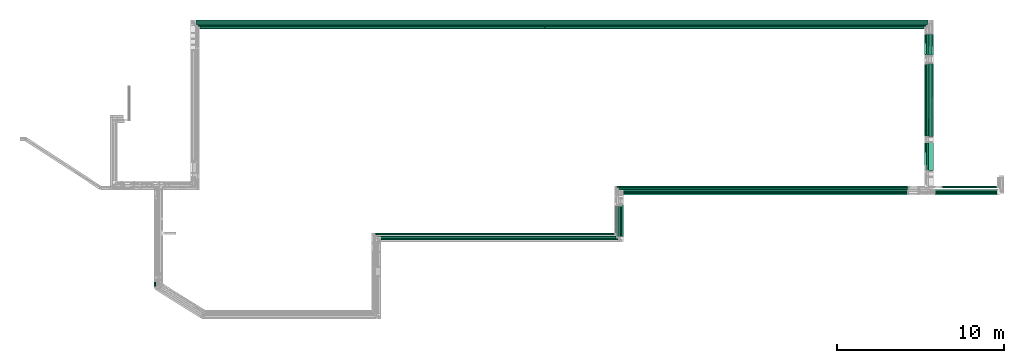
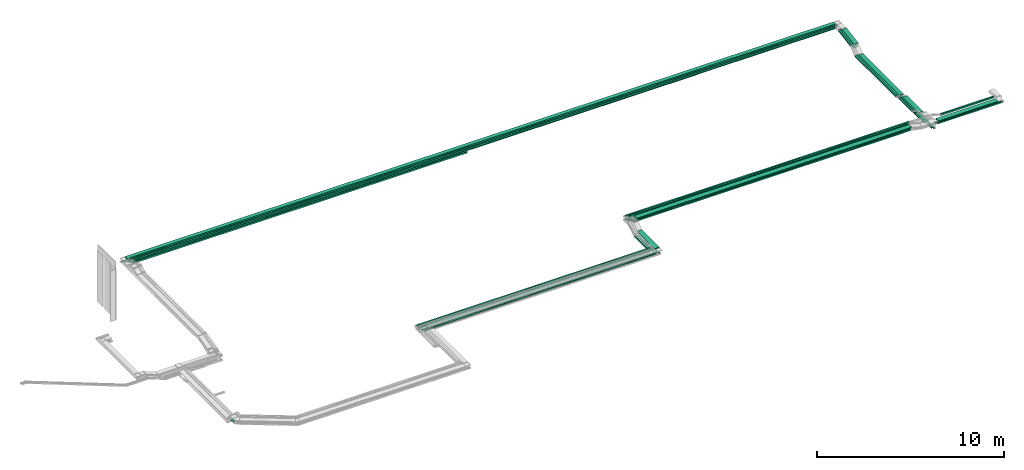
# One storey, part 2 of 14: 43 flow segments.
"""IFC2X3 building model written with IfcOpenShell, lengths in millimetres."""

from ifc_helpers import new_model, entity, si_unit, converted_unit, derived_unit, direction, frame, frame_2d, origin, origin_2d_with_axis, place, context, subcontext, project, spatial, rectangle, extrude, type_object, element, save


model = new_model("IFC2X3")

# Units and contexts
model_context = context("Model", 3, precision=0.01, world=origin(), true_north=direction((6.12303176911189e-17, 1.0)))
body_context = subcontext(model_context, "Body", "Model", "MODEL_VIEW")
ifc_project = project(units=[si_unit("LENGTHUNIT", "METRE", prefix="MILLI"), si_unit("AREAUNIT", "SQUARE_METRE"), si_unit("VOLUMEUNIT", "CUBIC_METRE"), converted_unit("PLANEANGLEUNIT", "DEGREE", entity("IfcRatioMeasure", 0.0174532925199433), si_unit("PLANEANGLEUNIT", "RADIAN"), dimensions=[0, 0, 0, 0, 0, 0, 0]), si_unit("MASSUNIT", "GRAM", prefix="KILO"), derived_unit("MASSDENSITYUNIT", [(si_unit("MASSUNIT", "GRAM", prefix="KILO"), 1), (si_unit("LENGTHUNIT", "METRE"), -3)]), derived_unit("MOMENTOFINERTIAUNIT", [(si_unit("LENGTHUNIT", "METRE"), 4)]), si_unit("TIMEUNIT", "SECOND"), si_unit("FREQUENCYUNIT", "HERTZ"), si_unit("THERMODYNAMICTEMPERATUREUNIT", "DEGREE_CELSIUS"), derived_unit("THERMALTRANSMITTANCEUNIT", [(si_unit("MASSUNIT", "GRAM", prefix="KILO"), 1), (si_unit("THERMODYNAMICTEMPERATUREUNIT", "KELVIN"), -1), (si_unit("TIMEUNIT", "SECOND"), -3)]), derived_unit("VOLUMETRICFLOWRATEUNIT", [(si_unit("LENGTHUNIT", "METRE"), 3), (si_unit("TIMEUNIT", "SECOND"), -1)]), derived_unit("MASSFLOWRATEUNIT", [(si_unit("MASSUNIT", "GRAM", prefix="KILO"), 1), (si_unit("TIMEUNIT", "SECOND"), -1)]), derived_unit("ROTATIONALFREQUENCYUNIT", [(si_unit("TIMEUNIT", "SECOND"), -1)]), si_unit("ELECTRICCURRENTUNIT", "AMPERE"), si_unit("ELECTRICVOLTAGEUNIT", "VOLT"), si_unit("POWERUNIT", "WATT"), si_unit("FORCEUNIT", "NEWTON", prefix="KILO"), si_unit("ILLUMINANCEUNIT", "LUX"), si_unit("LUMINOUSFLUXUNIT", "LUMEN"), si_unit("LUMINOUSINTENSITYUNIT", "CANDELA"), derived_unit("USERDEFINED", [(si_unit("MASSUNIT", "GRAM", prefix="KILO"), -1), (si_unit("LENGTHUNIT", "METRE"), -2), (si_unit("TIMEUNIT", "SECOND"), 3), (si_unit("LUMINOUSFLUXUNIT", "LUMEN"), 1)]), derived_unit("LINEARVELOCITYUNIT", [(si_unit("LENGTHUNIT", "METRE"), 1), (si_unit("TIMEUNIT", "SECOND"), -1)]), si_unit("PRESSUREUNIT", "PASCAL"), derived_unit("USERDEFINED", [(si_unit("LENGTHUNIT", "METRE"), -2), (si_unit("MASSUNIT", "GRAM", prefix="KILO"), 1), (si_unit("TIMEUNIT", "SECOND"), -2)]), derived_unit("LINEARFORCEUNIT", [(si_unit("MASSUNIT", "GRAM", prefix="KILO"), 1), (si_unit("LENGTHUNIT", "METRE"), 1), (si_unit("TIMEUNIT", "SECOND"), -2), (si_unit("LENGTHUNIT", "METRE"), -1)]), derived_unit("PLANARFORCEUNIT", [(si_unit("MASSUNIT", "GRAM", prefix="KILO"), 1), (si_unit("LENGTHUNIT", "METRE"), 1), (si_unit("TIMEUNIT", "SECOND"), -2), (si_unit("LENGTHUNIT", "METRE"), -2)])], contexts=[model_context])

# Site, building, storey
site_placement = place(None, origin())
site = spatial("IfcSite", under=ifc_project, at=site_placement, CompositionType="ELEMENT")
building_placement = place(site_placement, origin())
building = spatial("IfcBuilding", under=site, at=building_placement, CompositionType="ELEMENT")
storey_placement = place(building_placement, frame((0.0, 0.0, 19800.0)))
storey = spatial("IfcBuildingStorey", under=building, at=storey_placement, Name="06", CompositionType="ELEMENT", Elevation=19800.0)

# Flow segments
cable_carrier_segment_type = type_object("IfcCableCarrierSegmentType", PredefinedType="CABLETRAYSEGMENT")
flow_segment_1_placement = place(storey_placement, frame((20510.22, 19700.0, 3300.0)))
element("IfcFlowSegment", 1, at=flow_segment_1_placement, inside=storey, type_object=cable_carrier_segment_type, context=body_context, shape_type="SweptSolid", body=[
    extrude(rectangle(XDim=43861.6970823392, YDim=300.000000000001, at=origin_2d_with_axis()), frame((21930.85, 150.0, 0.0), z_axis=(3.27264479763197e-08, 0.0, 1.0), x_axis=(-1.0, 0.0, 3.27264479763197e-08)), (0.0, 0.0, 1.0), 49.9999999999973),
])
flow_segment_2_placement = place(storey_placement, frame((20615.22, 19595.0, 3300.0)))
element("IfcFlowSegment", 2, at=flow_segment_2_placement, inside=storey, type_object=cable_carrier_segment_type, context=body_context, shape_type="SweptSolid", body=[
    extrude(rectangle(XDim=43650.3107133575, YDim=100.000000000003, at=origin_2d_with_axis()), frame((21825.16, 50.0, 0.0), z_axis=(0.0, 0.0, 1.0), x_axis=(-1.0, 0.0, 0.0)), (0.0, 0.0, 1.0), 100.000000000003),
])
flow_segment_3_placement = place(storey_placement, frame((20720.22, 19490.0, 3300.0)))
element("IfcFlowSegment", 3, at=flow_segment_3_placement, inside=storey, type_object=cable_carrier_segment_type, context=body_context, shape_type="SweptSolid", body=[
    extrude(rectangle(XDim=43439.8425431613, YDim=100.000000000001, at=origin_2d_with_axis()), frame((21719.92, 50.0, 0.0), z_axis=(0.0, 0.0, 1.0), x_axis=(-1.0, 0.0, 0.0)), (0.0, 0.0, 1.0), 100.000000000003),
])
flow_segment_4_placement = place(storey_placement, frame((64593.04, 9615.0, 2550.0)))
element("IfcFlowSegment", 4, at=flow_segment_4_placement, inside=storey, type_object=cable_carrier_segment_type, context=body_context, shape_type="SweptSolid", body=[
    extrude(rectangle(XDim=7760.0992906484, YDim=99.9999999999946, at=origin_2d_with_axis()), frame((50.0, 3880.05, 0.0), z_axis=(0.0, 0.0, 1.0), x_axis=(0.0, -1.0, 0.0)), (0.0, 0.0, 1.0), 49.9999999999973),
])
flow_segment_5_placement = place(storey_placement, frame((64490.53, 9720.0, 2550.0)))
element("IfcFlowSegment", 5, at=flow_segment_5_placement, inside=storey, type_object=cable_carrier_segment_type, context=body_context, shape_type="SweptSolid", body=[
    extrude(rectangle(XDim=7655.09929065903, YDim=99.9999999999946, at=origin_2d_with_axis()), frame((50.0, 3827.55, 0.0), z_axis=(0.0, 0.0, 1.0), x_axis=(0.0, -1.0, 0.0)), (0.0, 0.0, 1.0), 49.9999999999973),
])
flow_segment_6_placement = place(storey_placement, frame((64388.57, 10290.0, 2550.0)))
element("IfcFlowSegment", 6, at=flow_segment_6_placement, inside=storey, type_object=cable_carrier_segment_type, context=body_context, shape_type="SweptSolid", body=[
    extrude(rectangle(XDim=7085.0992906527, YDim=99.9999999999946, at=origin_2d_with_axis()), frame((50.0, 3542.55, 0.0), z_axis=(0.0, 0.0, 1.0), x_axis=(0.0, -1.0, 0.0)), (0.0, 0.0, 1.0), 49.9999999999973),
])
flow_segment_7_placement = place(storey_placement, frame((20720.22, 19490.0, 3100.0)))
element("IfcFlowSegment", 7, at=flow_segment_7_placement, inside=storey, type_object=cable_carrier_segment_type, context=body_context, shape_type="SweptSolid", body=[
    extrude(rectangle(XDim=20698.7834674717, YDim=100.000000000001, at=origin_2d_with_axis()), frame((10349.39, 50.0, 0.0), z_axis=(0.0, 0.0, 1.0), x_axis=(-1.0, 0.0, 0.0)), (0.0, 0.0, 1.0), 100.000000000003),
])
flow_segment_8_placement = place(storey_placement, frame((20310.22, 19900.0, 3100.0)))
element("IfcFlowSegment", 8, at=flow_segment_8_placement, inside=storey, type_object=cable_carrier_segment_type, context=body_context, shape_type="SweptSolid", body=[
    extrude(rectangle(XDim=44262.8208978618, YDim=100.000000000003, at=origin_2d_with_axis()), frame((22131.41, 50.0, 0.0), z_axis=(0.0, 0.0, 1.0), x_axis=(-1.0, 0.0, 0.0)), (0.0, 0.0, 1.0), 49.9999999999973),
])
flow_segment_9_placement = place(storey_placement, frame((20415.22, 19795.0, 3100.0)))
element("IfcFlowSegment", 9, at=flow_segment_9_placement, inside=storey, type_object=cable_carrier_segment_type, context=body_context, shape_type="SweptSolid", body=[
    extrude(rectangle(XDim=44055.3107133575, YDim=100.000000000003, at=origin_2d_with_axis()), frame((22027.66, 50.0, 0.0), z_axis=(0.0, 0.0, 1.0), x_axis=(-1.0, 0.0, 0.0)), (0.0, 0.0, 1.0), 49.9999999999973),
])
flow_segment_10_placement = place(storey_placement, frame((20520.22, 19690.0, 3100.0)))
element("IfcFlowSegment", 10, at=flow_segment_10_placement, inside=storey, type_object=cable_carrier_segment_type, context=body_context, shape_type="SweptSolid", body=[
    extrude(rectangle(XDim=43848.3558915892, YDim=100.000000000003, at=origin_2d_with_axis()), frame((21924.18, 50.0, 0.0), z_axis=(0.0, 0.0, 1.0), x_axis=(-1.0, 0.0, 0.0)), (0.0, 0.0, 1.0), 49.9999999999973),
])
flow_segment_11_placement = place(storey_placement, frame((46136.39, 9515.0, 3175.0)))
element("IfcFlowSegment", 11, at=flow_segment_11_placement, inside=storey, type_object=cable_carrier_segment_type, context=body_context, shape_type="SweptSolid", body=[
    extrude(rectangle(XDim=17012.5626625772, YDim=300.000000000001, at=origin_2d_with_axis()), frame((8506.28, 150.0, 0.0), z_axis=(0.0, 6.09869900927148e-08, 1.0), x_axis=(-1.0, 0.0, 0.0)), (0.0, 0.0, 1.0), 50.0000000000017),
])
flow_segment_12_placement = place(storey_placement, frame((45715.12, 9945.0, 3175.0)))
element("IfcFlowSegment", 12, at=flow_segment_12_placement, inside=storey, type_object=cable_carrier_segment_type, context=body_context, shape_type="SweptSolid", body=[
    extrude(rectangle(XDim=17558.63871242, YDim=99.9999999999989, at=origin_2d_with_axis()), frame((8779.32, 50.0, 0.0), z_axis=(0.0, 0.0, 1.0), x_axis=(-1.0, 0.0, 0.0)), (0.0, 0.0, 1.0), 100.000000000003),
])
flow_segment_13_placement = place(storey_placement, frame((31167.89, 7125.0, 2800.0)))
element("IfcFlowSegment", 13, at=flow_segment_13_placement, inside=storey, type_object=cable_carrier_segment_type, context=body_context, shape_type="SweptSolid", body=[
    extrude(rectangle(XDim=14407.2299237504, YDim=100.000000000001, at=origin_2d_with_axis()), frame((7203.61, 50.0, 0.0), z_axis=(0.0, 0.0, 1.0), x_axis=(-1.0, 0.0, 0.0)), (0.0, 0.0, 1.0), 100.000000000003),
])
for number, where in (
    (14, (31481.5, 6822.78, 2600.0)),
    (15, (31369.29, 6927.78, 2600.0)),
):
    element("IfcFlowSegment", number, at=place(storey_placement, frame(where)), inside=storey, type_object=cable_carrier_segment_type, context=body_context, shape_type="SweptSolid", body=[
        extrude(rectangle(XDim=14320.0, YDim=99.9999999999989, at=origin_2d_with_axis()), frame((7160.0, 50.0, 0.0), z_axis=(0.0, 0.0, 1.0), x_axis=(-1.0, 0.0, 0.0)), (0.0, 0.0, 1.0), 49.9999999999973),
    ])
flow_segment_14_placement = place(storey_placement, frame((31245.11, 7125.0, 2600.0)))
element("IfcFlowSegment", 16, at=flow_segment_14_placement, inside=storey, type_object=cable_carrier_segment_type, context=body_context, shape_type="SweptSolid", body=[
    extrude(rectangle(XDim=14330.0132597468, YDim=99.9999999999989, at=origin_2d_with_axis()), frame((7165.01, 50.0, 0.0), z_axis=(0.0, 0.0, 1.0), x_axis=(-1.0, 0.0, 0.0)), (0.0, 0.0, 1.0), 100.000000000003),
])
flow_segment_15_placement = place(storey_placement, frame((64391.91, 17890.77, 3082.61)))
element("IfcFlowSegment", 17, at=flow_segment_15_placement, inside=storey, type_object=cable_carrier_segment_type, context=body_context, shape_type="SweptSolid", body=[
    extrude(rectangle(XDim=49.9999999999963, YDim=1283.81748851725, at=frame_2d((0.0, 0.0), x_axis=(0.0, 1.0))), frame((0.0, 636.96, 132.7), z_axis=(1.0, 0.0, 0.0), x_axis=(0.0, -0.985728987268031, -0.168340023938282)), (0.0, 0.0, 1.0), 300.000000000001),
])
for number, where in (
    (18, (64285.53, 17888.86, 3083.36)),
    (19, (64180.06, 17888.86, 3083.36)),
):
    element("IfcFlowSegment", number, at=place(storey_placement, frame(where)), inside=storey, type_object=cable_carrier_segment_type, context=body_context, shape_type="SweptSolid", body=[
        extrude(rectangle(XDim=100.000000000001, YDim=99.9999999999946, at=origin_2d_with_axis()), frame((50.0, 8.42, 49.29), z_axis=(0.0, 0.985728987268031, 0.168340023938282), x_axis=(0.0, -0.168340023938282, 0.985728987268031)), (0.0, 0.0, 1.0), 1277.24793927283),
    ])
for number, where in (
    (20, (64593.04, 17882.63, 2877.81)),
    (21, (64490.53, 17882.63, 2877.81)),
    (22, (64388.57, 17882.63, 2877.81)),
):
    element("IfcFlowSegment", number, at=place(storey_placement, frame(where)), inside=storey, type_object=cable_carrier_segment_type, context=body_context, shape_type="SweptSolid", body=[
        extrude(rectangle(XDim=49.9999999999963, YDim=1312.36750384491, at=frame_2d((0.0, 0.0), x_axis=(0.0, 1.0))), frame((0.0, 651.03, 135.11), z_axis=(1.0, 0.0, 0.0), x_axis=(0.0, -0.985728987268033, -0.168340023938271)), (0.0, 0.0, 1.0), 99.9999999999945),
    ])
flow_segment_16_placement = place(storey_placement, frame((64285.55, 10981.49, 2800.0)))
element("IfcFlowSegment", 23, at=flow_segment_16_placement, inside=storey, type_object=cable_carrier_segment_type, context=body_context, shape_type="SweptSolid", body=[
    extrude(rectangle(XDim=1669.27622341284, YDim=99.999999999908, at=origin_2d_with_axis()), frame((50.0, 834.65, 0.09), z_axis=(0.0, -0.000110170861433383, 0.999999993931191), x_axis=(0.0, 0.999999993931191, 0.000110170861433383)), (0.0, 0.0, 1.0), 99.9999999999068),
])
flow_segment_17_placement = place(storey_placement, frame((64180.06, 11289.13, 2800.0)))
element("IfcFlowSegment", 24, at=flow_segment_17_placement, inside=storey, type_object=cable_carrier_segment_type, context=body_context, shape_type="SweptSolid", body=[
    extrude(rectangle(XDim=1361.64006742099, YDim=99.9999999999946, at=origin_2d_with_axis()), frame((50.0, 680.83, 0.09), z_axis=(0.0, -0.000133755597263879, 0.99999999105472), x_axis=(0.0, 0.99999999105472, 0.000133755597263879)), (0.0, 0.0, 1.0), 99.9999999999964),
])
flow_segment_18_placement = place(storey_placement, frame((64393.04, 10968.1, 2800.0)))
element("IfcFlowSegment", 25, at=flow_segment_18_placement, inside=storey, type_object=cable_carrier_segment_type, context=body_context, shape_type="SweptSolid", body=[
    extrude(rectangle(XDim=1687.04298934208, YDim=300.000000000001, at=origin_2d_with_axis()), frame((150.0, 843.52, 0.0), z_axis=(0.0, 0.0, 1.0), x_axis=(0.0, 1.0, 0.0)), (0.0, 0.0, 1.0), 49.9999999999973),
])
flow_segment_19_placement = place(storey_placement, frame((45595.12, 7245.0, 2600.0)))
element("IfcFlowSegment", 26, at=flow_segment_19_placement, inside=storey, type_object=cable_carrier_segment_type, context=body_context, shape_type="SweptSolid", body=[
    extrude(rectangle(XDim=1580.56637967652, YDim=99.9999999999946, at=origin_2d_with_axis()), frame((50.0, 790.28, 0.0), z_axis=(0.0, 0.0, 1.0), x_axis=(0.0, 1.0, 0.0)), (0.0, 0.0, 1.0), 100.000000000003),
])
flow_segment_20_placement = place(storey_placement, frame((45709.29, 7047.78, 2600.0)))
element("IfcFlowSegment", 27, at=flow_segment_20_placement, inside=storey, type_object=cable_carrier_segment_type, context=body_context, shape_type="SweptSolid", body=[
    extrude(rectangle(XDim=1790.25375258002, YDim=99.9999999999946, at=origin_2d_with_axis()), frame((50.0, 895.13, 0.0), z_axis=(0.0, 0.0, 1.0), x_axis=(0.0, 1.0, 0.0)), (0.0, 0.0, 1.0), 49.999999999993),
])
flow_segment_21_placement = place(storey_placement, frame((45821.5, 6942.78, 2600.0)))
element("IfcFlowSegment", 28, at=flow_segment_21_placement, inside=storey, type_object=cable_carrier_segment_type, context=body_context, shape_type="SweptSolid", body=[
    extrude(rectangle(XDim=1895.25375258002, YDim=99.9999999999946, at=origin_2d_with_axis()), frame((50.0, 947.63, 0.0), z_axis=(0.0, 0.0, 1.0), x_axis=(0.0, 1.0, 0.0)), (0.0, 0.0, 1.0), 50.0000000000016),
])
flow_segment_22_placement = place(storey_placement, frame((45934.76, 6837.78, 2600.0)))
element("IfcFlowSegment", 29, at=flow_segment_22_placement, inside=storey, type_object=cable_carrier_segment_type, context=body_context, shape_type="SweptSolid", body=[
    extrude(rectangle(XDim=2000.25375258002, YDim=99.9999999999946, at=origin_2d_with_axis()), frame((50.0, 1000.13, 0.0), z_axis=(0.0, 0.0, 1.0), x_axis=(0.0, 1.0, 0.0)), (0.0, 0.0, 1.0), 49.999999999993),
])
flow_segment_23_placement = place(storey_placement, frame((45816.39, 7037.78, 2800.0)))
element("IfcFlowSegment", 30, at=flow_segment_23_placement, inside=storey, type_object=cable_carrier_segment_type, context=body_context, shape_type="SweptSolid", body=[
    extrude(rectangle(XDim=1884.43926960423, YDim=300.000000000001, at=origin_2d_with_axis()), frame((150.0, 942.22, 0.0), z_axis=(0.0, 0.0, 1.0), x_axis=(0.0, 1.0, 0.0)), (0.0, 0.0, 1.0), 49.9999999999973),
])
flow_segment_24_placement = place(storey_placement, frame((18007.14, 4020.35, 3000.0)))
element("IfcFlowSegment", 31, at=flow_segment_24_placement, inside=storey, type_object=cable_carrier_segment_type, context=body_context, shape_type="SweptSolid", body=[
    extrude(rectangle(XDim=303.89022785907, YDim=99.9999999999989, at=origin_2d_with_axis()), frame((50.0, 151.95, 0.0), z_axis=(0.0, 0.0, 1.0), x_axis=(0.0, 1.0, 0.0)), (0.0, 0.0, 1.0), 49.9999999999973),
])
flow_segment_25_placement = place(storey_placement, frame((64823.04, 9615.0, 2800.0)))
element("IfcFlowSegment", 32, at=flow_segment_25_placement, inside=storey, type_object=cable_carrier_segment_type, context=body_context, shape_type="SweptSolid", body=[
    extrude(rectangle(XDim=3987.54391835811, YDim=100.000000000001, at=origin_2d_with_axis()), frame((1993.77, 50.0, 0.0)), (0.0, 0.0, 1.0), 49.9999999999973),
])
flow_segment_26_placement = place(storey_placement, frame((64720.53, 9720.0, 2800.0)))
element("IfcFlowSegment", 33, at=flow_segment_26_placement, inside=storey, type_object=cable_carrier_segment_type, context=body_context, shape_type="SweptSolid", body=[
    extrude(rectangle(XDim=3976.91068107751, YDim=99.9999999999989, at=origin_2d_with_axis()), frame((1988.46, 50.0, 0.0)), (0.0, 0.0, 1.0), 49.9999999999973),
])
flow_segment_27_placement = place(storey_placement, frame((65228.96, 9945.0, 3000.0)))
element("IfcFlowSegment", 34, at=flow_segment_27_placement, inside=storey, type_object=cable_carrier_segment_type, context=body_context, shape_type="SweptSolid", body=[
    extrude(rectangle(XDim=3274.30346905501, YDim=99.9999999999989, at=origin_2d_with_axis()), frame((1637.15, 50.0, 0.0)), (0.0, 0.0, 1.0), 100.000000000003),
])
flow_segment_28_placement = place(storey_placement, frame((45829.29, 9836.0, 3175.0)))
element("IfcFlowSegment", 35, at=flow_segment_28_placement, inside=storey, type_object=cable_carrier_segment_type, context=body_context, shape_type="SweptSolid", body=[
    extrude(rectangle(XDim=17320.17589421, YDim=100.000000000001, at=origin_2d_with_axis()), frame((8660.09, 50.0, 0.0), z_axis=(-1.88655445451045e-09, 2.03663483944181e-07, 1.0), x_axis=(-1.0, 0.0, -1.8865544545043e-09)), (0.0, 0.0, 1.0), 99.9999999999967),
])
flow_segment_29_placement = place(storey_placement, frame((45715.12, 9945.0, 2950.0)))
element("IfcFlowSegment", 36, at=flow_segment_29_placement, inside=storey, type_object=cable_carrier_segment_type, context=body_context, shape_type="SweptSolid", body=[
    extrude(rectangle(XDim=17434.9052265142, YDim=99.9999999999989, at=origin_2d_with_axis()), frame((8717.45, 50.0, 0.0), z_axis=(0.0, 0.0, 1.0), x_axis=(-1.0, 0.0, 0.0)), (0.0, 0.0, 1.0), 100.000000000003),
])
flow_segment_30_placement = place(storey_placement, frame((45829.29, 9825.0, 2950.0)))
element("IfcFlowSegment", 37, at=flow_segment_30_placement, inside=storey, type_object=cable_carrier_segment_type, context=body_context, shape_type="SweptSolid", body=[
    extrude(rectangle(XDim=17326.3300603298, YDim=99.9999999999989, at=origin_2d_with_axis()), frame((8663.17, 50.0, 0.0), z_axis=(0.0, 0.0, 1.0), x_axis=(-1.0, 0.0, 0.0)), (0.0, 0.0, 1.0), 49.9999999999973),
])
flow_segment_31_placement = place(storey_placement, frame((45941.5, 9720.0, 2950.0)))
element("IfcFlowSegment", 38, at=flow_segment_31_placement, inside=storey, type_object=cable_carrier_segment_type, context=body_context, shape_type="SweptSolid", body=[
    extrude(rectangle(XDim=17216.2477546201, YDim=99.9999999999989, at=origin_2d_with_axis()), frame((8608.12, 50.0, 0.0), z_axis=(0.0, 0.0, 1.0), x_axis=(-1.0, 0.0, 0.0)), (0.0, 0.0, 1.0), 49.9999999999973),
])
flow_segment_32_placement = place(storey_placement, frame((46054.76, 9615.0, 2950.0)))
element("IfcFlowSegment", 39, at=flow_segment_32_placement, inside=storey, type_object=cable_carrier_segment_type, context=body_context, shape_type="SweptSolid", body=[
    extrude(rectangle(XDim=17117.3462182917, YDim=100.000000000001, at=origin_2d_with_axis()), frame((8558.67, 50.0, 0.0), z_axis=(0.0, 0.0, 1.0), x_axis=(-1.0, 0.0, 0.0)), (0.0, 0.0, 1.0), 49.9999999999973),
])
flow_segment_33_placement = place(storey_placement, frame((64391.92, 13008.63, 2700.0)))
element("IfcFlowSegment", 40, at=flow_segment_33_placement, inside=storey, type_object=cable_carrier_segment_type, context=body_context, shape_type="SweptSolid", body=[
    extrude(rectangle(XDim=4374.71884293394, YDim=300.000000000004, at=origin_2d_with_axis()), frame((150.56, 2187.4, 0.0), z_axis=(0.0, 0.0, 1.0), x_axis=(0.000254693966544882, -0.999999967565491, 0.0)), (0.0, 0.0, 1.0), 49.999999999993),
])
flow_segment_34_placement = place(storey_placement, frame((64285.55, 13019.25, 2700.19)))
element("IfcFlowSegment", 41, at=flow_segment_34_placement, inside=storey, type_object=cable_carrier_segment_type, context=body_context, shape_type="SweptSolid", body=[
    extrude(rectangle(XDim=4338.3016544712, YDim=99.999999841948, at=origin_2d_with_axis()), frame((50.0, 2169.15, 0.0), z_axis=(0.0, -2.64388587007212e-07, 1.0), x_axis=(0.0, 1.0, 2.64388587007212e-07)), (0.0, 0.0, 1.0), 99.9999998419428),
])
flow_segment_35_placement = place(storey_placement, frame((64180.06, 13019.25, 2700.19)))
element("IfcFlowSegment", 42, at=flow_segment_35_placement, inside=storey, type_object=cable_carrier_segment_type, context=body_context, shape_type="SweptSolid", body=[
    extrude(rectangle(XDim=4338.30020865616, YDim=99.9999999999951, at=origin_2d_with_axis()), frame((50.0, 2169.15, 0.0), z_axis=(0.0, 0.0, 1.0), x_axis=(-9.64493498738689e-08, 1.0, 0.0)), (0.0, 0.0, 1.0), 100.000000000003),
])
flow_segment_36_placement = place(storey_placement, frame((64823.04, 9515.0, 3000.0)))
element("IfcFlowSegment", 43, at=flow_segment_36_placement, inside=storey, type_object=cable_carrier_segment_type, context=body_context, shape_type="SweptSolid", body=[
    extrude(rectangle(XDim=3679.75388627882, YDim=300.000000000001, at=origin_2d_with_axis()), frame((1839.88, 150.0, 0.0)), (0.0, 0.0, 1.0), 49.9999999999973),
])

save(model, "model.ifc")
